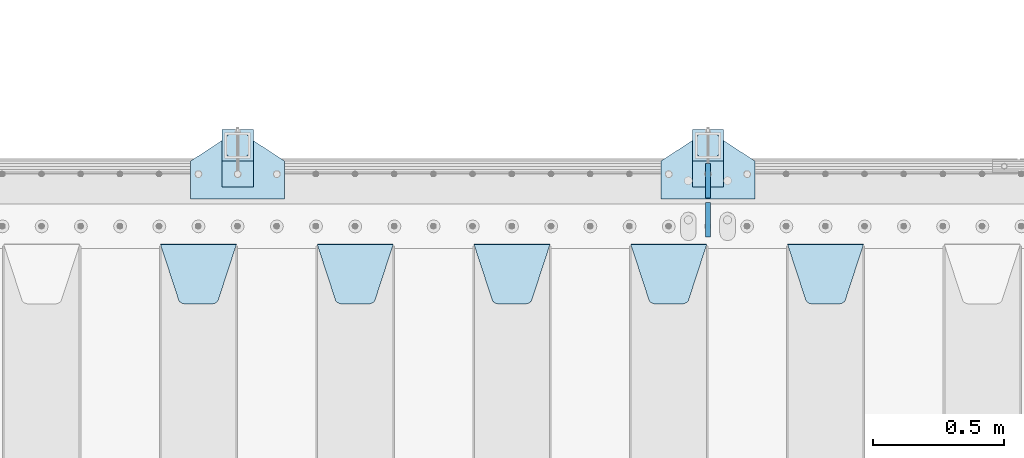
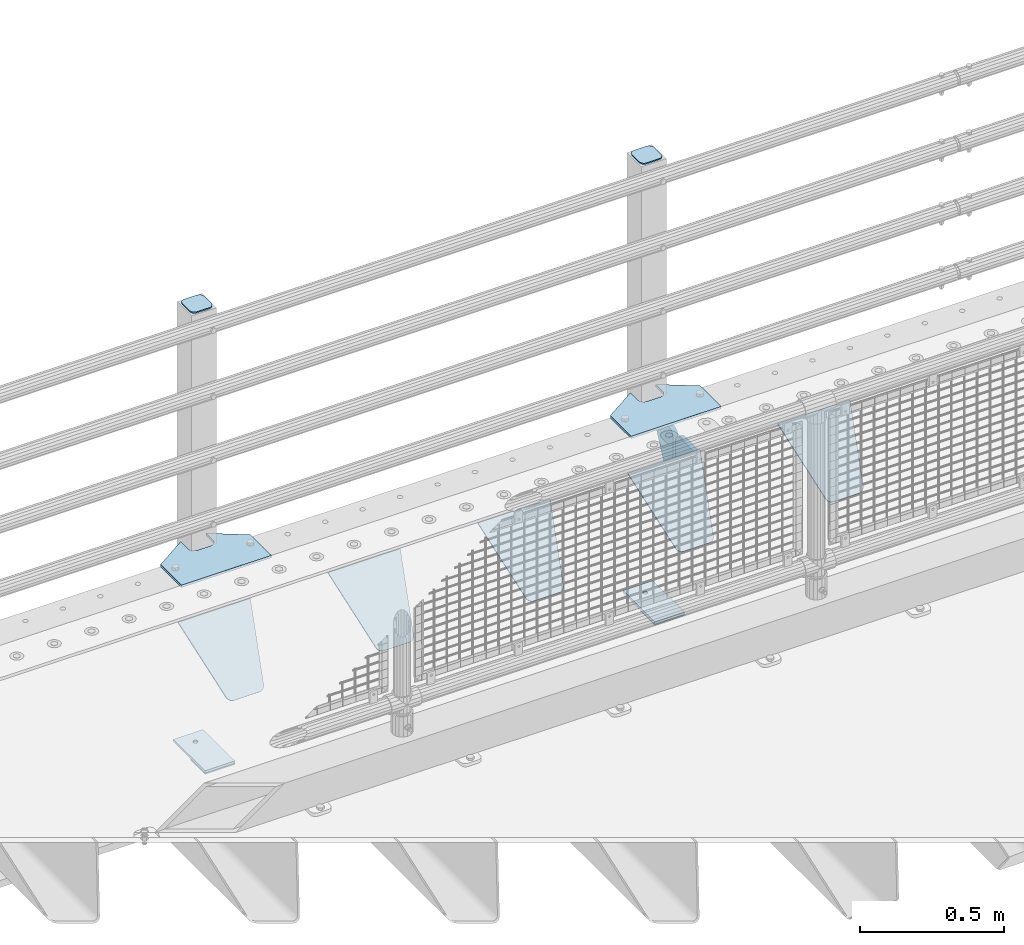
# One storey, part 215 of 240: 15 plates.
"""IFC2X3 building model written with IfcOpenShell, lengths in millimetres."""

from ifc_helpers import new_model, si_unit, frame, origin_with_axes, place, context, subcontext, project, spatial, faceted_brep, material, type_object, element, save


model = new_model("IFC2X3")

# Units and contexts
model_context = context("Model", 3, precision=1e-05, world=origin_with_axes())
body_context = subcontext(model_context, "Body", "Model", "MODEL_VIEW")
ifc_project = project(units=[si_unit("LENGTHUNIT", "METRE", prefix="MILLI"), si_unit("AREAUNIT", "SQUARE_METRE"), si_unit("VOLUMEUNIT", "CUBIC_METRE"), si_unit("MASSUNIT", "GRAM", prefix="KILO"), si_unit("TIMEUNIT", "SECOND"), si_unit("PLANEANGLEUNIT", "RADIAN"), si_unit("SOLIDANGLEUNIT", "STERADIAN"), si_unit("THERMODYNAMICTEMPERATUREUNIT", "DEGREE_CELSIUS"), si_unit("LUMINOUSINTENSITYUNIT", "LUMEN")], contexts=[model_context])

# Site, building, storey
site_placement = place(None, origin_with_axes())
site = spatial("IfcSite", under=ifc_project, at=site_placement, CompositionType="ELEMENT")
building_placement = place(site_placement, origin_with_axes())
building = spatial("IfcBuilding", under=site, at=building_placement, Name="Standard", CompositionType="ELEMENT")
storey_placement = place(building_placement, origin_with_axes())
storey = spatial("IfcBuildingStorey", under=building, at=storey_placement, Name="Undefined", CompositionType="ELEMENT", Elevation=0.0)

# Plates
ifc_material_1 = material(Name="STEEL/S355N")
plate_type_1 = type_object("IfcPlateType", PredefinedType="NOTDEFINED")
plate_1_placement = place(storey_placement, frame((46905.0, 35831.767766956, -1.76776695296758), z_axis=(0.0, -0.707106781186547, -0.707106781186548), x_axis=(1.0, 0.0, 0.0)))
element("IfcPlate", 1, at=plate_1_placement, inside=storey, type_object=plate_type_1, material=ifc_material_1, context=body_context, shape_type="Brep", body=[
    faceted_brep([(0.0, -2.5, 0.0), (69.345504679477, -2.50000000000364, 300.171731424827), (69.345504679477, 2.49999999999636, 300.171731424827), (0.0, 2.5, 0.0), (70.927406119954, -2.50000000000364, 304.897442415397), (70.927406119954, 2.49999999999636, 304.897442415397), (73.3818627772271, -2.50000000000728, 309.234538108525), (73.3818627772271, 2.49999999999636, 309.234538108529), (76.6187032999587, -2.50000000000728, 313.023683126099), (76.6187032999587, 2.49999999999636, 313.023683126103), (80.5190132705029, -2.50000000000364, 316.125672595368), (80.5190132705029, 2.49999999999636, 316.125672595368), (84.9395038596849, -2.50000000000364, 318.426546230472), (84.9395038596849, 2.49999999999636, 318.426546230472), (89.7177759439219, -2.5, 319.841774983277), (89.7177759439219, 2.49999999999636, 319.841774983273), (94.6782862926484, -2.50000000000364, 320.319366455074), (94.6782862926484, 2.49999999999636, 320.319366455074), (195.321713707352, -2.50000000000364, 320.319366455074), (195.321713707352, 2.49999999999636, 320.319366455074), (200.282224056078, -2.50000000000364, 319.841774983273), (200.282224056078, 2.49999999999636, 319.841774983273), (205.060496140315, -2.50000000000364, 318.426546230472), (205.060496140315, 2.49999999999636, 318.426546230472), (209.480986729497, -2.50000000000364, 316.125672595368), (209.480986729497, 2.49999999999636, 316.125672595368), (213.381296700041, -2.50000000000728, 313.023683126099), (213.381296700041, 2.49999999999272, 313.023683126099), (216.618137222766, -2.50000000000364, 309.234538108522), (216.618137222766, 2.49999999999636, 309.234538108522), (219.072593880039, -2.50000000000364, 304.897442415397), (219.072593880039, 2.49999999999636, 304.897442415397), (220.654495320523, -2.50000000000364, 300.171731424827), (220.654495320523, 2.49999999999636, 300.171731424827), (290.0, -2.50000000000364, -3.63797880709171e-12), (290.0, 2.49999999999636, -3.63797880709171e-12)], [[[0, 1, 2, 3]], [[1, 4, 5, 2]], [[4, 6, 7, 5]], [[6, 8, 9, 7]], [[8, 10, 11, 9]], [[10, 12, 13, 11]], [[12, 14, 15, 13]], [[14, 16, 17, 15]], [[16, 18, 19, 17]], [[18, 20, 21, 19]], [[20, 22, 23, 21]], [[22, 24, 25, 23]], [[24, 26, 27, 25]], [[26, 28, 29, 27]], [[28, 30, 31, 29]], [[30, 32, 33, 31]], [[32, 34, 35, 33]], [[34, 0, 3, 35]], [[5, 7, 9, 11, 13, 15, 17, 19, 21, 23, 25, 27, 29, 31, 33, 35, 3, 2]], [[34, 32, 30, 28, 26, 24, 22, 20, 18, 16, 14, 12, 10, 8, 6, 4, 1, 0]]]),
])
plate_2_placement = place(storey_placement, frame((46305.0, 35831.767766956, -1.76776695296758), z_axis=(0.0, -0.707106781186547, -0.707106781186548), x_axis=(1.0, 0.0, 0.0)))
element("IfcPlate", 2, at=plate_2_placement, inside=storey, type_object=plate_type_1, material=ifc_material_1, context=body_context, shape_type="Brep", body=[
    faceted_brep([(0.0, -2.5, 0.0), (69.345504679477, -2.50000000000364, 300.171731424827), (69.345504679477, 2.49999999999636, 300.171731424827), (0.0, 2.5, 0.0), (70.927406119954, -2.50000000000364, 304.897442415397), (70.927406119954, 2.49999999999636, 304.897442415397), (73.3818627772271, -2.50000000000728, 309.234538108525), (73.3818627772271, 2.49999999999636, 309.234538108529), (76.6187032999587, -2.50000000000728, 313.023683126099), (76.6187032999587, 2.49999999999636, 313.023683126103), (80.5190132705029, -2.50000000000364, 316.125672595368), (80.5190132705029, 2.49999999999636, 316.125672595368), (84.9395038596849, -2.50000000000364, 318.426546230472), (84.9395038596849, 2.49999999999636, 318.426546230472), (89.7177759439219, -2.5, 319.841774983277), (89.7177759439219, 2.49999999999636, 319.841774983273), (94.6782862926484, -2.50000000000364, 320.319366455074), (94.6782862926484, 2.49999999999636, 320.319366455074), (195.321713707352, -2.50000000000364, 320.319366455074), (195.321713707352, 2.49999999999636, 320.319366455074), (200.282224056078, -2.50000000000364, 319.841774983273), (200.282224056078, 2.49999999999636, 319.841774983273), (205.060496140315, -2.50000000000364, 318.426546230472), (205.060496140315, 2.49999999999636, 318.426546230472), (209.480986729497, -2.50000000000364, 316.125672595368), (209.480986729497, 2.49999999999636, 316.125672595368), (213.381296700041, -2.50000000000728, 313.023683126099), (213.381296700041, 2.49999999999272, 313.023683126099), (216.618137222766, -2.50000000000364, 309.234538108522), (216.618137222766, 2.49999999999636, 309.234538108522), (219.072593880039, -2.50000000000364, 304.897442415397), (219.072593880039, 2.49999999999636, 304.897442415397), (220.654495320523, -2.50000000000364, 300.171731424827), (220.654495320523, 2.49999999999636, 300.171731424827), (290.0, -2.50000000000364, -3.63797880709171e-12), (290.0, 2.49999999999636, -3.63797880709171e-12)], [[[0, 1, 2, 3]], [[1, 4, 5, 2]], [[4, 6, 7, 5]], [[6, 8, 9, 7]], [[8, 10, 11, 9]], [[10, 12, 13, 11]], [[12, 14, 15, 13]], [[14, 16, 17, 15]], [[16, 18, 19, 17]], [[18, 20, 21, 19]], [[20, 22, 23, 21]], [[22, 24, 25, 23]], [[24, 26, 27, 25]], [[26, 28, 29, 27]], [[28, 30, 31, 29]], [[30, 32, 33, 31]], [[32, 34, 35, 33]], [[34, 0, 3, 35]], [[5, 7, 9, 11, 13, 15, 17, 19, 21, 23, 25, 27, 29, 31, 33, 35, 3, 2]], [[34, 32, 30, 28, 26, 24, 22, 20, 18, 16, 14, 12, 10, 8, 6, 4, 1, 0]]]),
])
plate_3_placement = place(storey_placement, frame((45705.0, 35831.767766956, -1.76776695296758), z_axis=(0.0, -0.707106781186547, -0.707106781186548), x_axis=(1.0, 0.0, 0.0)))
element("IfcPlate", 3, at=plate_3_placement, inside=storey, type_object=plate_type_1, material=ifc_material_1, context=body_context, shape_type="Brep", body=[
    faceted_brep([(0.0, -2.5, 0.0), (69.345504679477, -2.50000000000364, 300.171731424827), (69.345504679477, 2.49999999999636, 300.171731424827), (0.0, 2.5, 0.0), (70.927406119954, -2.50000000000364, 304.897442415397), (70.927406119954, 2.49999999999636, 304.897442415397), (73.3818627772271, -2.50000000000728, 309.234538108525), (73.3818627772271, 2.49999999999636, 309.234538108529), (76.6187032999587, -2.50000000000728, 313.023683126099), (76.6187032999587, 2.49999999999636, 313.023683126103), (80.5190132705029, -2.50000000000364, 316.125672595368), (80.5190132705029, 2.49999999999636, 316.125672595368), (84.9395038596849, -2.50000000000364, 318.426546230472), (84.9395038596849, 2.49999999999636, 318.426546230472), (89.7177759439219, -2.5, 319.841774983277), (89.7177759439219, 2.49999999999636, 319.841774983273), (94.6782862926484, -2.50000000000364, 320.319366455074), (94.6782862926484, 2.49999999999636, 320.319366455074), (195.321713707352, -2.50000000000364, 320.319366455074), (195.321713707352, 2.49999999999636, 320.319366455074), (200.282224056078, -2.50000000000364, 319.841774983273), (200.282224056078, 2.49999999999636, 319.841774983273), (205.060496140315, -2.50000000000364, 318.426546230472), (205.060496140315, 2.49999999999636, 318.426546230472), (209.480986729497, -2.50000000000364, 316.125672595368), (209.480986729497, 2.49999999999636, 316.125672595368), (213.381296700041, -2.50000000000728, 313.023683126099), (213.381296700041, 2.49999999999272, 313.023683126099), (216.618137222766, -2.50000000000364, 309.234538108522), (216.618137222766, 2.49999999999636, 309.234538108522), (219.072593880039, -2.50000000000364, 304.897442415397), (219.072593880039, 2.49999999999636, 304.897442415397), (220.654495320523, -2.50000000000364, 300.171731424827), (220.654495320523, 2.49999999999636, 300.171731424827), (290.0, -2.50000000000364, -3.63797880709171e-12), (290.0, 2.49999999999636, -3.63797880709171e-12)], [[[0, 1, 2, 3]], [[1, 4, 5, 2]], [[4, 6, 7, 5]], [[6, 8, 9, 7]], [[8, 10, 11, 9]], [[10, 12, 13, 11]], [[12, 14, 15, 13]], [[14, 16, 17, 15]], [[16, 18, 19, 17]], [[18, 20, 21, 19]], [[20, 22, 23, 21]], [[22, 24, 25, 23]], [[24, 26, 27, 25]], [[26, 28, 29, 27]], [[28, 30, 31, 29]], [[30, 32, 33, 31]], [[32, 34, 35, 33]], [[34, 0, 3, 35]], [[5, 7, 9, 11, 13, 15, 17, 19, 21, 23, 25, 27, 29, 31, 33, 35, 3, 2]], [[34, 32, 30, 28, 26, 24, 22, 20, 18, 16, 14, 12, 10, 8, 6, 4, 1, 0]]]),
])
plate_4_placement = place(storey_placement, frame((45105.0, 35831.767766956, -1.76776695296758), z_axis=(0.0, -0.707106781186547, -0.707106781186548), x_axis=(1.0, 0.0, 0.0)))
element("IfcPlate", 4, at=plate_4_placement, inside=storey, type_object=plate_type_1, material=ifc_material_1, context=body_context, shape_type="Brep", body=[
    faceted_brep([(0.0, -2.5, 0.0), (69.345504679477, -2.50000000000364, 300.171731424827), (69.345504679477, 2.49999999999636, 300.171731424827), (0.0, 2.5, 0.0), (70.927406119954, -2.50000000000364, 304.897442415397), (70.927406119954, 2.49999999999636, 304.897442415397), (73.3818627772271, -2.50000000000728, 309.234538108525), (73.3818627772271, 2.49999999999636, 309.234538108529), (76.6187032999587, -2.50000000000728, 313.023683126099), (76.6187032999587, 2.49999999999636, 313.023683126103), (80.5190132705029, -2.50000000000364, 316.125672595368), (80.5190132705029, 2.49999999999636, 316.125672595368), (84.9395038596849, -2.50000000000364, 318.426546230472), (84.9395038596849, 2.49999999999636, 318.426546230472), (89.7177759439219, -2.5, 319.841774983277), (89.7177759439219, 2.49999999999636, 319.841774983273), (94.6782862926484, -2.50000000000364, 320.319366455074), (94.6782862926484, 2.49999999999636, 320.319366455074), (195.321713707352, -2.50000000000364, 320.319366455074), (195.321713707352, 2.49999999999636, 320.319366455074), (200.282224056078, -2.50000000000364, 319.841774983273), (200.282224056078, 2.49999999999636, 319.841774983273), (205.060496140315, -2.50000000000364, 318.426546230472), (205.060496140315, 2.49999999999636, 318.426546230472), (209.480986729497, -2.50000000000364, 316.125672595368), (209.480986729497, 2.49999999999636, 316.125672595368), (213.381296700041, -2.50000000000728, 313.023683126099), (213.381296700041, 2.49999999999272, 313.023683126099), (216.618137222766, -2.50000000000364, 309.234538108522), (216.618137222766, 2.49999999999636, 309.234538108522), (219.072593880039, -2.50000000000364, 304.897442415397), (219.072593880039, 2.49999999999636, 304.897442415397), (220.654495320523, -2.50000000000364, 300.171731424827), (220.654495320523, 2.49999999999636, 300.171731424827), (290.0, -2.50000000000364, -3.63797880709171e-12), (290.0, 2.49999999999636, -3.63797880709171e-12)], [[[0, 1, 2, 3]], [[1, 4, 5, 2]], [[4, 6, 7, 5]], [[6, 8, 9, 7]], [[8, 10, 11, 9]], [[10, 12, 13, 11]], [[12, 14, 15, 13]], [[14, 16, 17, 15]], [[16, 18, 19, 17]], [[18, 20, 21, 19]], [[20, 22, 23, 21]], [[22, 24, 25, 23]], [[24, 26, 27, 25]], [[26, 28, 29, 27]], [[28, 30, 31, 29]], [[30, 32, 33, 31]], [[32, 34, 35, 33]], [[34, 0, 3, 35]], [[5, 7, 9, 11, 13, 15, 17, 19, 21, 23, 25, 27, 29, 31, 33, 35, 3, 2]], [[34, 32, 30, 28, 26, 24, 22, 20, 18, 16, 14, 12, 10, 8, 6, 4, 1, 0]]]),
])
plate_5_placement = place(storey_placement, frame((44505.0, 35831.767766956, -1.76776695296758), z_axis=(0.0, -0.707106781186547, -0.707106781186548), x_axis=(1.0, 0.0, 0.0)))
element("IfcPlate", 5, at=plate_5_placement, inside=storey, type_object=plate_type_1, material=ifc_material_1, context=body_context, shape_type="Brep", body=[
    faceted_brep([(0.0, -2.5, 0.0), (69.345504679477, -2.50000000000364, 300.171731424827), (69.345504679477, 2.49999999999636, 300.171731424827), (0.0, 2.5, 0.0), (70.927406119954, -2.50000000000364, 304.897442415397), (70.927406119954, 2.49999999999636, 304.897442415397), (73.3818627772271, -2.50000000000728, 309.234538108525), (73.3818627772271, 2.49999999999636, 309.234538108529), (76.6187032999587, -2.50000000000728, 313.023683126099), (76.6187032999587, 2.49999999999636, 313.023683126103), (80.5190132705029, -2.50000000000364, 316.125672595368), (80.5190132705029, 2.49999999999636, 316.125672595368), (84.9395038596849, -2.50000000000364, 318.426546230472), (84.9395038596849, 2.49999999999636, 318.426546230472), (89.7177759439219, -2.5, 319.841774983277), (89.7177759439219, 2.49999999999636, 319.841774983273), (94.6782862926484, -2.50000000000364, 320.319366455074), (94.6782862926484, 2.49999999999636, 320.319366455074), (195.321713707352, -2.50000000000364, 320.319366455074), (195.321713707352, 2.49999999999636, 320.319366455074), (200.282224056078, -2.50000000000364, 319.841774983273), (200.282224056078, 2.49999999999636, 319.841774983273), (205.060496140315, -2.50000000000364, 318.426546230472), (205.060496140315, 2.49999999999636, 318.426546230472), (209.480986729497, -2.50000000000364, 316.125672595368), (209.480986729497, 2.49999999999636, 316.125672595368), (213.381296700041, -2.50000000000728, 313.023683126099), (213.381296700041, 2.49999999999272, 313.023683126099), (216.618137222766, -2.50000000000364, 309.234538108522), (216.618137222766, 2.49999999999636, 309.234538108522), (219.072593880039, -2.50000000000364, 304.897442415397), (219.072593880039, 2.49999999999636, 304.897442415397), (220.654495320523, -2.50000000000364, 300.171731424827), (220.654495320523, 2.49999999999636, 300.171731424827), (290.0, -2.50000000000364, -3.63797880709171e-12), (290.0, 2.49999999999636, -3.63797880709171e-12)], [[[0, 1, 2, 3]], [[1, 4, 5, 2]], [[4, 6, 7, 5]], [[6, 8, 9, 7]], [[8, 10, 11, 9]], [[10, 12, 13, 11]], [[12, 14, 15, 13]], [[14, 16, 17, 15]], [[16, 18, 19, 17]], [[18, 20, 21, 19]], [[20, 22, 23, 21]], [[22, 24, 25, 23]], [[24, 26, 27, 25]], [[26, 28, 29, 27]], [[28, 30, 31, 29]], [[30, 32, 33, 31]], [[32, 34, 35, 33]], [[34, 0, 3, 35]], [[5, 7, 9, 11, 13, 15, 17, 19, 21, 23, 25, 27, 29, 31, 33, 35, 3, 2]], [[34, 32, 30, 28, 26, 24, 22, 20, 18, 16, 14, 12, 10, 8, 6, 4, 1, 0]]]),
])
plate_type_2 = type_object("IfcPlateType", PredefinedType="NOTDEFINED")
for number, where, z_axis, x_axis in (
    (6, (46600.0, 35860.0, -30.0), (0.0, 0.0, -1.0), (0.0, 1.0, 0.0)),
    (7, (46600.0, 36140.0, -30.0), (0.0, 0.0, -1.0), (0.0, -1.0, 0.0)),
):
    element("IfcPlate", number, at=place(storey_placement, frame(where, z_axis=z_axis, x_axis=x_axis)), inside=storey, type_object=plate_type_2, material=ifc_material_1, context=body_context, shape_type="Brep", body=[
        faceted_brep([(0.0, -10.0, 0.0), (0.0, -10.0, 30.0), (0.0, 10.0, 30.0), (0.0, 10.0, 0.0), (102.0, -10.0, 250.0), (102.0, 10.0, 250.0), (132.0, -10.0, 250.0), (132.0, 10.0, 250.0), (132.0, -10.0, 30.0), (132.0, 10.0, 30.0), (131.544232590368, -10.0, 24.790554669992), (131.544232590368, 10.0, 24.790554669992), (130.190778623579, -10.0, 19.7393957002299), (130.190778623579, 10.0, 19.7393957002299), (127.980762113533, -10.0, 15.0), (127.980762113533, 10.0, 15.0), (124.98133329357, -10.0, 10.7163717094038), (124.98133329357, 10.0, 10.7163717094038), (121.283628290596, -10.0, 7.01866670643062), (121.283628290596, 10.0, 7.01866670643062), (117.0, -10.0, 4.01923788646684), (117.0, 10.0, 4.01923788646684), (112.260604299769, -10.0, 1.80922137642278), (112.260604299769, 10.0, 1.80922137642278), (107.209445330009, -10.0, 0.455767409633722), (107.209445330009, 10.0, 0.455767409633722), (102.0, -10.0, 0.0), (102.0, 10.0, 0.0)], [[[0, 1, 2, 3]], [[1, 4, 5, 2]], [[4, 6, 7, 5]], [[6, 8, 9, 7]], [[8, 10, 11, 9]], [[10, 12, 13, 11]], [[12, 14, 15, 13]], [[14, 16, 17, 15]], [[16, 18, 19, 17]], [[18, 20, 21, 19]], [[20, 22, 23, 21]], [[22, 24, 25, 23]], [[24, 26, 27, 25]], [[26, 0, 3, 27]], [[5, 7, 9, 11, 13, 15, 17, 19, 21, 23, 25, 27, 3, 2]], [[26, 24, 22, 20, 18, 16, 14, 12, 10, 8, 6, 4, 1, 0]]]),
    ])
ifc_material_2 = material(Name="STEEL/S355J2")
plate_type_3 = type_object("IfcPlateType", PredefinedType="NOTDEFINED")
plate_6_placement = place(storey_placement, frame((46420.0, 36005.0, 5.00000000004911), z_axis=(0.0, 1.0, 0.0), x_axis=(1.0, 0.0, 0.0)))
element("IfcPlate", 8, at=plate_6_placement, inside=storey, type_object=plate_type_3, material=ifc_material_2, context=body_context, shape_type="Brep", body=[
    faceted_brep([(0.0, -5.0, 0.0), (2.31396552408114e-06, -5.0, 145.0), (2.31396552408114e-06, 5.0, 145.0), (0.0, 5.0, 0.0), (130.0, -5.0, 230.0), (130.0, 5.0, 230.0), (130.0, -5.0, 180.0), (130.0, 5.0, 180.0), (130.48036798992, -5.0, 175.122741949599), (130.48036798992, 5.0, 175.122741949599), (131.903011687216, -5.0, 170.432914190875), (131.903011687216, 5.0, 170.432914190875), (134.213259692435, -5.0, 166.110744174512), (134.213259692435, 5.0, 166.110744174512), (137.322330470335, -5.0, 162.322330470335), (137.322330470335, 5.0, 162.322330470335), (141.110744174512, -5.0, 159.213259692435), (141.110744174512, 5.0, 159.213259692435), (145.432914190875, -5.0, 156.903011687216), (145.432914190875, 5.0, 156.903011687216), (150.122741949599, -5.0, 155.48036798992), (150.122741949599, 5.0, 155.48036798992), (155.0, -5.0, 155.0), (155.0, 5.0, 155.0), (205.0, -5.0, 155.0), (205.0, 5.0, 155.0), (209.877258050401, -5.0, 155.48036798992), (209.877258050401, 5.0, 155.48036798992), (214.567085809125, -5.0, 156.903011687216), (214.567085809125, 5.0, 156.903011687216), (218.889255825488, -5.0, 159.213259692435), (218.889255825488, 5.0, 159.213259692435), (222.677669529665, -5.0, 162.322330470335), (222.677669529665, 5.0, 162.322330470335), (225.786740307565, -5.0, 166.110744174512), (225.786740307565, 5.0, 166.110744174512), (228.096988312784, -5.0, 170.432914190875), (228.096988312784, 5.0, 170.432914190875), (229.51963201008, -5.0, 175.122741949599), (229.51963201008, 5.0, 175.122741949599), (230.0, -5.0, 180.0), (230.0, 5.0, 180.0), (230.0, -5.0, 230.0), (230.0, 5.0, 230.0), (360.0, -5.0, 145.0), (360.0, 5.0, 145.0), (360.0, -5.0, -7.27595761418343e-12), (360.0, 5.0, -7.27595761418343e-12)], [[[0, 1, 2, 3]], [[1, 4, 5, 2]], [[4, 6, 7, 5]], [[6, 8, 9, 7]], [[8, 10, 11, 9]], [[10, 12, 13, 11]], [[12, 14, 15, 13]], [[14, 16, 17, 15]], [[16, 18, 19, 17]], [[18, 20, 21, 19]], [[20, 22, 23, 21]], [[22, 24, 25, 23]], [[24, 26, 27, 25]], [[26, 28, 29, 27]], [[28, 30, 31, 29]], [[30, 32, 33, 31]], [[32, 34, 35, 33]], [[34, 36, 37, 35]], [[36, 38, 39, 37]], [[38, 40, 41, 39]], [[40, 42, 43, 41]], [[42, 44, 45, 43]], [[44, 46, 47, 45]], [[46, 0, 3, 47]], [[5, 7, 9, 11, 13, 15, 17, 19, 21, 23, 25, 27, 29, 31, 33, 35, 37, 39, 41, 43, 45, 47, 3, 2]], [[46, 44, 42, 40, 38, 36, 34, 32, 30, 28, 26, 24, 22, 20, 18, 16, 14, 12, 10, 8, 6, 4, 1, 0]]]),
])
plate_7_placement = place(storey_placement, frame((44620.0, 36005.0, 5.00000000004911), z_axis=(0.0, 1.0, 0.0), x_axis=(1.0, 0.0, 0.0)))
element("IfcPlate", 9, at=plate_7_placement, inside=storey, type_object=plate_type_3, material=ifc_material_2, context=body_context, shape_type="Brep", body=[
    faceted_brep([(0.0, -5.0, 0.0), (2.31396552408114e-06, -5.0, 145.0), (2.31396552408114e-06, 5.0, 145.0), (0.0, 5.0, 0.0), (130.0, -5.0, 230.0), (130.0, 5.0, 230.0), (130.0, -5.0, 180.0), (130.0, 5.0, 180.0), (130.48036798992, -5.0, 175.122741949599), (130.48036798992, 5.0, 175.122741949599), (131.903011687216, -5.0, 170.432914190875), (131.903011687216, 5.0, 170.432914190875), (134.213259692435, -5.0, 166.110744174512), (134.213259692435, 5.0, 166.110744174512), (137.322330470335, -5.0, 162.322330470335), (137.322330470335, 5.0, 162.322330470335), (141.110744174512, -5.0, 159.213259692435), (141.110744174512, 5.0, 159.213259692435), (145.432914190875, -5.0, 156.903011687216), (145.432914190875, 5.0, 156.903011687216), (150.122741949599, -5.0, 155.48036798992), (150.122741949599, 5.0, 155.48036798992), (155.0, -5.0, 155.0), (155.0, 5.0, 155.0), (205.0, -5.0, 155.0), (205.0, 5.0, 155.0), (209.877258050401, -5.0, 155.48036798992), (209.877258050401, 5.0, 155.48036798992), (214.567085809125, -5.0, 156.903011687216), (214.567085809125, 5.0, 156.903011687216), (218.889255825488, -5.0, 159.213259692435), (218.889255825488, 5.0, 159.213259692435), (222.677669529665, -5.0, 162.322330470335), (222.677669529665, 5.0, 162.322330470335), (225.786740307565, -5.0, 166.110744174512), (225.786740307565, 5.0, 166.110744174512), (228.096988312784, -5.0, 170.432914190875), (228.096988312784, 5.0, 170.432914190875), (229.51963201008, -5.0, 175.122741949599), (229.51963201008, 5.0, 175.122741949599), (230.0, -5.0, 180.0), (230.0, 5.0, 180.0), (230.0, -5.0, 230.0), (230.0, 5.0, 230.0), (360.0, -5.0, 145.0), (360.0, 5.0, 145.0), (360.0, -5.0, -7.27595761418343e-12), (360.0, 5.0, -7.27595761418343e-12)], [[[0, 1, 2, 3]], [[1, 4, 5, 2]], [[4, 6, 7, 5]], [[6, 8, 9, 7]], [[8, 10, 11, 9]], [[10, 12, 13, 11]], [[12, 14, 15, 13]], [[14, 16, 17, 15]], [[16, 18, 19, 17]], [[18, 20, 21, 19]], [[20, 22, 23, 21]], [[22, 24, 25, 23]], [[24, 26, 27, 25]], [[26, 28, 29, 27]], [[28, 30, 31, 29]], [[30, 32, 33, 31]], [[32, 34, 35, 33]], [[34, 36, 37, 35]], [[36, 38, 39, 37]], [[38, 40, 41, 39]], [[40, 42, 43, 41]], [[42, 44, 45, 43]], [[44, 46, 47, 45]], [[46, 0, 3, 47]], [[5, 7, 9, 11, 13, 15, 17, 19, 21, 23, 25, 27, 29, 31, 33, 35, 37, 39, 41, 43, 45, 47, 3, 2]], [[46, 44, 42, 40, 38, 36, 34, 32, 30, 28, 26, 24, 22, 20, 18, 16, 14, 12, 10, 8, 6, 4, 1, 0]]]),
])
plate_type_4 = type_object("IfcPlateType", PredefinedType="NOTDEFINED")
for number, where, z_axis, x_axis in (
    (10, (46540.0000000001, 36050.0000000002, -850.000000000002), (0.0, 1.0, 0.0), (1.0, 0.0, 0.0)),
    (11, (44740.0000000001, 36050.0000000002, -850.000000000002), (0.0, 1.0, 0.0), (1.0, 0.0, 0.0)),
):
    element("IfcPlate", number, at=place(storey_placement, frame(where, z_axis=z_axis, x_axis=x_axis)), inside=storey, type_object=plate_type_4, material=ifc_material_2, context=body_context, shape_type="Brep", body=[
        faceted_brep([(66.3639610305399, -5.0, 163.636038969111), (66.3639610305399, 5.0, 163.636038969111), (59.9999999998618, 5.0, 160.999999999789), (59.9999999998618, -5.0, 160.999999999789), (53.6360389691836, 5.0, 163.636038969111), (53.6360389691836, -5.0, 163.636038969111), (50.9999999998618, 5.0, 169.999999999789), (50.9999999998618, -5.0, 169.999999999789), (53.6360389691836, 5.0, 176.363961030467), (53.6360389691836, -5.0, 176.363961030467), (59.9999999998618, 5.0, 178.999999999789), (59.9999999998618, -5.0, 178.999999999789), (66.3639610305399, 5.0, 176.363961030467), (66.3639610305399, -5.0, 176.363961030467), (68.9999999998618, 5.0, 169.999999999789), (68.9999999998618, -5.0, 169.999999999789), (120.0, -5.0, 0.0), (120.0, -5.0, 220.0), (0.0, -5.0, 220.0), (0.0, -5.0, 0.0), (0.0, 5.0, 0.0), (120.0, 5.0, 0.0), (120.0, 5.0, 220.0), (0.0, 5.0, 220.0)], [[[0, 1, 2, 3]], [[3, 2, 4, 5]], [[5, 4, 6, 7]], [[7, 6, 8, 9]], [[9, 8, 10, 11]], [[11, 10, 12, 13]], [[13, 12, 14, 15]], [[15, 14, 1, 0]], [[16, 17, 18, 19], [3, 5, 7, 9, 11, 13, 15, 0]], [[16, 19, 20, 21]], [[17, 16, 21, 22]], [[18, 17, 22, 23]], [[19, 18, 23, 20]], [[22, 21, 20, 23], [10, 8, 6, 4, 2, 1, 14, 12]]]),
    ])
plate_type_5 = type_object("IfcPlateType", PredefinedType="NOTDEFINED")
plate_8_placement = place(storey_placement, frame((46644.0000000001, 36166.0000000002, 1012.50000000001), z_axis=(0.0, 1.0, 0.0), x_axis=(-1.0, 0.0, 0.0)))
element("IfcPlate", 12, at=plate_8_placement, inside=storey, type_object=plate_type_5, material=ifc_material_2, context=body_context, shape_type="Brep", body=[
    faceted_brep([(0.0, -2.5, 19.0), (0.0, -2.5, 69.0), (0.0, 2.5, 69.0), (0.0, 2.5, 19.0), (0.476369668547704, -2.5, 73.2278977451715), (0.476369668547704, 2.5, 73.2278977451715), (1.88159150985302, -2.5, 77.2437910432345), (1.88159150985302, 2.5, 77.2437910432345), (4.14520183311106, -2.5, 80.8463062353185), (4.14520183311106, 2.5, 80.8463062353185), (7.15369376468152, -2.5, 83.8547981668889), (7.15369376468152, 2.5, 83.8547981668889), (10.7562089567655, -2.5, 86.118408490147), (10.7562089567655, 2.5, 86.118408490147), (14.7721022548285, -2.5, 87.5236303314523), (14.7721022548285, 2.5, 87.5236303314523), (19.0, -2.5, 88.0), (19.0, 2.5, 88.0), (69.0, -2.5, 88.0), (69.0, 2.5, 88.0), (73.2278977451715, -2.5, 87.5236303314523), (73.2278977451715, 2.5, 87.5236303314523), (77.2437910432345, -2.5, 86.118408490147), (77.2437910432345, 2.5, 86.118408490147), (80.8463062353185, -2.5, 83.8547981668889), (80.8463062353185, 2.5, 83.8547981668889), (83.8547981668889, -2.5, 80.8463062353185), (83.8547981668889, 2.5, 80.8463062353185), (86.118408490147, -2.5, 77.2437910432345), (86.118408490147, 2.5, 77.2437910432345), (87.5236303314523, -2.5, 73.2278977451715), (87.5236303314523, 2.5, 73.2278977451715), (88.0, -2.5, 69.0), (88.0, 2.5, 69.0), (88.0, -2.5, 19.0), (88.0, 2.5, 19.0), (87.5236303314523, -2.5, 14.7721022548285), (87.5236303314523, 2.5, 14.7721022548285), (86.118408490147, -2.5, 10.7562089567655), (86.118408490147, 2.5, 10.7562089567655), (83.8547981668889, -2.5, 7.15369376468152), (83.8547981668889, 2.5, 7.15369376468152), (80.8463062353185, -2.5, 4.14520183311106), (80.8463062353185, 2.5, 4.14520183311106), (77.2437910432345, -2.5, 1.88159150985302), (77.2437910432345, 2.5, 1.88159150985302), (73.2278977451715, -2.5, 0.476369668547704), (73.2278977451715, 2.5, 0.476369668547704), (69.0, -2.5, 0.0), (69.0, 2.5, 0.0), (19.0, -2.5, 0.0), (19.0, 2.5, 0.0), (14.7721022548285, -2.5, 0.476369668547704), (14.7721022548285, 2.5, 0.476369668547704), (10.7562089567655, -2.5, 1.88159150985302), (10.7562089567655, 2.5, 1.88159150985302), (7.15369376468152, -2.5, 4.14520183311106), (7.15369376468152, 2.5, 4.14520183311106), (4.14520183311106, -2.5, 7.15369376468152), (4.14520183311106, 2.5, 7.15369376468152), (1.88159150985302, -2.5, 10.7562089567655), (1.88159150985302, 2.5, 10.7562089567655), (0.476369668547704, -2.5, 14.7721022548285), (0.476369668547704, 2.5, 14.7721022548285)], [[[0, 1, 2, 3]], [[1, 4, 5, 2]], [[4, 6, 7, 5]], [[6, 8, 9, 7]], [[8, 10, 11, 9]], [[10, 12, 13, 11]], [[12, 14, 15, 13]], [[14, 16, 17, 15]], [[16, 18, 19, 17]], [[18, 20, 21, 19]], [[20, 22, 23, 21]], [[22, 24, 25, 23]], [[24, 26, 27, 25]], [[26, 28, 29, 27]], [[28, 30, 31, 29]], [[30, 32, 33, 31]], [[32, 34, 35, 33]], [[34, 36, 37, 35]], [[36, 38, 39, 37]], [[38, 40, 41, 39]], [[40, 42, 43, 41]], [[42, 44, 45, 43]], [[44, 46, 47, 45]], [[46, 48, 49, 47]], [[48, 50, 51, 49]], [[50, 52, 53, 51]], [[52, 54, 55, 53]], [[54, 56, 57, 55]], [[56, 58, 59, 57]], [[58, 60, 61, 59]], [[60, 62, 63, 61]], [[62, 0, 3, 63]], [[5, 7, 9, 11, 13, 15, 17, 19, 21, 23, 25, 27, 29, 31, 33, 35, 37, 39, 41, 43, 45, 47, 49, 51, 53, 55, 57, 59, 61, 63, 3, 2]], [[62, 60, 58, 56, 54, 52, 50, 48, 46, 44, 42, 40, 38, 36, 34, 32, 30, 28, 26, 24, 22, 20, 18, 16, 14, 12, 10, 8, 6, 4, 1, 0]]]),
])
plate_9_placement = place(storey_placement, frame((44844.0000000001, 36166.0000000002, 1012.50000000001), z_axis=(0.0, 1.0, 0.0), x_axis=(-1.0, 0.0, 0.0)))
element("IfcPlate", 13, at=plate_9_placement, inside=storey, type_object=plate_type_5, material=ifc_material_2, context=body_context, shape_type="Brep", body=[
    faceted_brep([(0.0, -2.5, 19.0), (0.0, -2.5, 69.0), (0.0, 2.5, 69.0), (0.0, 2.5, 19.0), (0.476369668547704, -2.5, 73.2278977451715), (0.476369668547704, 2.5, 73.2278977451715), (1.88159150985302, -2.5, 77.2437910432345), (1.88159150985302, 2.5, 77.2437910432345), (4.14520183311106, -2.5, 80.8463062353185), (4.14520183311106, 2.5, 80.8463062353185), (7.15369376468152, -2.5, 83.8547981668889), (7.15369376468152, 2.5, 83.8547981668889), (10.7562089567655, -2.5, 86.118408490147), (10.7562089567655, 2.5, 86.118408490147), (14.7721022548285, -2.5, 87.5236303314523), (14.7721022548285, 2.5, 87.5236303314523), (19.0, -2.5, 88.0), (19.0, 2.5, 88.0), (69.0, -2.5, 88.0), (69.0, 2.5, 88.0), (73.2278977451715, -2.5, 87.5236303314523), (73.2278977451715, 2.5, 87.5236303314523), (77.2437910432345, -2.5, 86.118408490147), (77.2437910432345, 2.5, 86.118408490147), (80.8463062353185, -2.5, 83.8547981668889), (80.8463062353185, 2.5, 83.8547981668889), (83.8547981668889, -2.5, 80.8463062353185), (83.8547981668889, 2.5, 80.8463062353185), (86.118408490147, -2.5, 77.2437910432345), (86.118408490147, 2.5, 77.2437910432345), (87.5236303314523, -2.5, 73.2278977451715), (87.5236303314523, 2.5, 73.2278977451715), (88.0, -2.5, 69.0), (88.0, 2.5, 69.0), (88.0, -2.5, 19.0), (88.0, 2.5, 19.0), (87.5236303314523, -2.5, 14.7721022548285), (87.5236303314523, 2.5, 14.7721022548285), (86.118408490147, -2.5, 10.7562089567655), (86.118408490147, 2.5, 10.7562089567655), (83.8547981668889, -2.5, 7.15369376468152), (83.8547981668889, 2.5, 7.15369376468152), (80.8463062353185, -2.5, 4.14520183311106), (80.8463062353185, 2.5, 4.14520183311106), (77.2437910432345, -2.5, 1.88159150985302), (77.2437910432345, 2.5, 1.88159150985302), (73.2278977451715, -2.5, 0.476369668547704), (73.2278977451715, 2.5, 0.476369668547704), (69.0, -2.5, 0.0), (69.0, 2.5, 0.0), (19.0, -2.5, 0.0), (19.0, 2.5, 0.0), (14.7721022548285, -2.5, 0.476369668547704), (14.7721022548285, 2.5, 0.476369668547704), (10.7562089567655, -2.5, 1.88159150985302), (10.7562089567655, 2.5, 1.88159150985302), (7.15369376468152, -2.5, 4.14520183311106), (7.15369376468152, 2.5, 4.14520183311106), (4.14520183311106, -2.5, 7.15369376468152), (4.14520183311106, 2.5, 7.15369376468152), (1.88159150985302, -2.5, 10.7562089567655), (1.88159150985302, 2.5, 10.7562089567655), (0.476369668547704, -2.5, 14.7721022548285), (0.476369668547704, 2.5, 14.7721022548285)], [[[0, 1, 2, 3]], [[1, 4, 5, 2]], [[4, 6, 7, 5]], [[6, 8, 9, 7]], [[8, 10, 11, 9]], [[10, 12, 13, 11]], [[12, 14, 15, 13]], [[14, 16, 17, 15]], [[16, 18, 19, 17]], [[18, 20, 21, 19]], [[20, 22, 23, 21]], [[22, 24, 25, 23]], [[24, 26, 27, 25]], [[26, 28, 29, 27]], [[28, 30, 31, 29]], [[30, 32, 33, 31]], [[32, 34, 35, 33]], [[34, 36, 37, 35]], [[36, 38, 39, 37]], [[38, 40, 41, 39]], [[40, 42, 43, 41]], [[42, 44, 45, 43]], [[44, 46, 47, 45]], [[46, 48, 49, 47]], [[48, 50, 51, 49]], [[50, 52, 53, 51]], [[52, 54, 55, 53]], [[54, 56, 57, 55]], [[56, 58, 59, 57]], [[58, 60, 61, 59]], [[60, 62, 63, 61]], [[62, 0, 3, 63]], [[5, 7, 9, 11, 13, 15, 17, 19, 21, 23, 25, 27, 29, 31, 33, 35, 37, 39, 41, 43, 45, 47, 49, 51, 53, 55, 57, 59, 61, 63, 3, 2]], [[62, 60, 58, 56, 54, 52, 50, 48, 46, 44, 42, 40, 38, 36, 34, 32, 30, 28, 26, 24, 22, 20, 18, 16, 14, 12, 10, 8, 6, 4, 1, 0]]]),
])
plate_type_6 = type_object("IfcPlateType", PredefinedType="NOTDEFINED")
for number, where, z_axis, x_axis in (
    (14, (46540.0000000001, 36050.0000000002, -857.500000000002), (0.0, 1.0, 0.0), (1.0, 0.0, 0.0)),
    (15, (44740.0000000001, 36050.0000000002, -857.500000000002), (0.0, 1.0, 0.0), (1.0, 0.0, 0.0)),
):
    element("IfcPlate", number, at=place(storey_placement, frame(where, z_axis=z_axis, x_axis=x_axis)), inside=storey, type_object=plate_type_6, material=ifc_material_2, context=body_context, shape_type="Brep", body=[
        faceted_brep([(0.0, -2.5, 0.0), (0.0, -2.5, 100.0), (0.0, 2.5, 100.0), (0.0, 2.5, 0.0), (120.0, -2.5, 100.0), (120.0, 2.5, 100.0), (120.0, -2.5, 0.0), (120.0, 2.5, 0.0)], [[[0, 1, 2, 3]], [[1, 4, 5, 2]], [[4, 6, 7, 5]], [[6, 0, 3, 7]], [[5, 7, 3, 2]], [[6, 4, 1, 0]]]),
    ])

save(model, "model.ifc")
